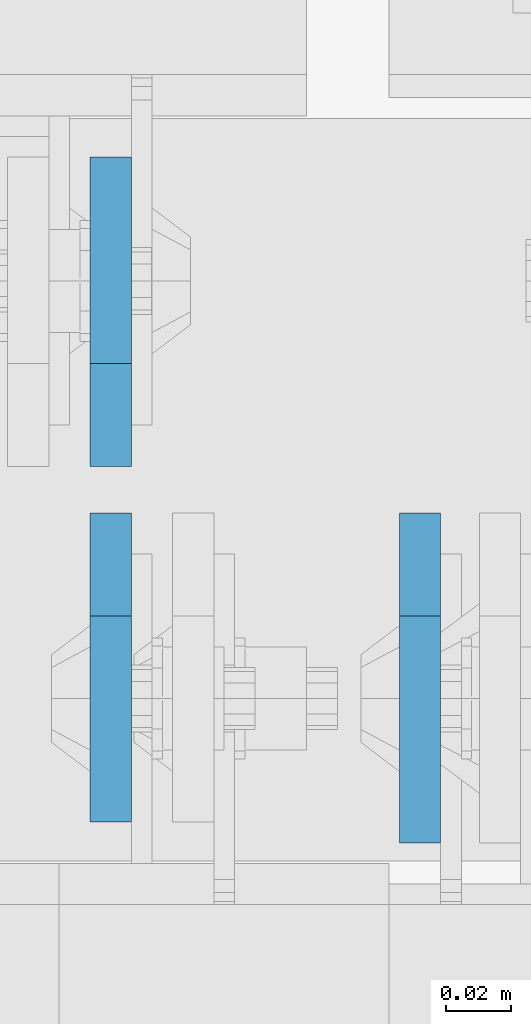
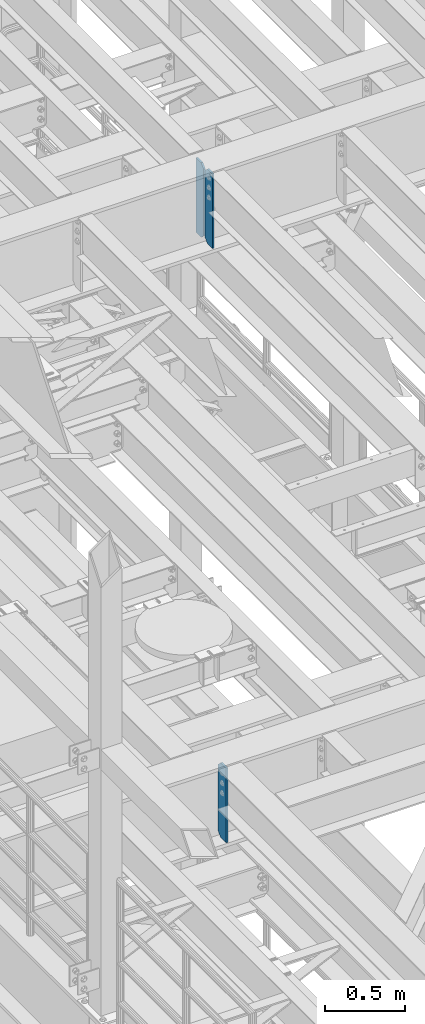
# One storey, part 1561 of 1876: 3 plates, 2 elements without a shape of their own.
"""IFC2X3 building model written with IfcOpenShell, lengths in millimetres."""

from ifc_helpers import new_model, si_unit, frame, origin_with_axes, place, context, subcontext, project, spatial, faceted_brep, material, type_object, element, aggregate, save


model = new_model("IFC2X3")

# Units and contexts
model_context = context("Model", 3, precision=1e-05, world=origin_with_axes())
body_context = subcontext(model_context, "Body", "Model", "MODEL_VIEW")
ifc_project = project(units=[si_unit("LENGTHUNIT", "METRE", prefix="MILLI"), si_unit("AREAUNIT", "SQUARE_METRE"), si_unit("VOLUMEUNIT", "CUBIC_METRE"), si_unit("MASSUNIT", "GRAM", prefix="KILO"), si_unit("TIMEUNIT", "SECOND"), si_unit("PLANEANGLEUNIT", "RADIAN"), si_unit("SOLIDANGLEUNIT", "STERADIAN"), si_unit("THERMODYNAMICTEMPERATUREUNIT", "DEGREE_CELSIUS"), si_unit("LUMINOUSINTENSITYUNIT", "LUMEN")], contexts=[model_context])

# Site, building, storey
site_placement = place(None, origin_with_axes())
site = spatial("IfcSite", under=ifc_project, at=site_placement, CompositionType="ELEMENT")
building_placement = place(site_placement, origin_with_axes())
building = spatial("IfcBuilding", under=site, at=building_placement, Name="Undefined", CompositionType="ELEMENT")
storey_placement = place(building_placement, origin_with_axes())
storey = spatial("IfcBuildingStorey", under=building, at=storey_placement, Name="Undefined", CompositionType="ELEMENT", Elevation=0.0)

# Assembly, plates
assembly_1_placement = place(storey_placement, origin_with_axes())
assembly_1 = element("IfcElementAssembly", 1, at=assembly_1_placement, inside=storey, Name="BEAM", AssemblyPlace="NOTDEFINED", PredefinedType="RIGID_FRAME")
ifc_material = material(Name="STEEL/A36")
plate_type_1 = type_object("IfcPlateType", PredefinedType="NOTDEFINED")
plate_1_placement = place(assembly_1_placement, frame((1895.47499990463, 1516.85625, 21959.8875), z_axis=(0.0, 0.0, 1.0), x_axis=(0.0, -1.0, 0.0)))
plate_1 = element("IfcPlate", 2, at=plate_1_placement, type_object=plate_type_1, material=ifc_material, Name="PLATE", context=body_context, shape_type="Brep", body=[
    faceted_brep([(0.0, -6.34999999999991, 31.75), (0.0, -6.35000000000036, 538.162475585938), (0.0, 6.35000000000036, 538.162475585938), (0.0, 6.34999999999991, 31.75), (31.75, -6.35000000000036, 569.912475585938), (31.75, 6.35000000000036, 569.912475585938), (95.25, -6.35000000000036, 569.912475585938), (95.25, 6.35000000000036, 569.912475585938), (95.25, -6.35000000000036, 0.0), (95.25, 6.35000000000036, 0.0), (31.75, -6.34999999999991, 0.0), (31.75, 6.34999999999991, 0.0)], [[[0, 1, 2, 3]], [[1, 4, 5, 2]], [[4, 6, 7, 5]], [[6, 8, 9, 7]], [[8, 10, 11, 9]], [[10, 0, 3, 11]], [[5, 7, 9, 11, 3, 2]], [[10, 8, 6, 4, 1, 0]]]),
])
plate_2_placement = place(assembly_1_placement, frame((1895.47499990463, 1531.14375, 21959.8875), z_axis=(0.0, 0.0, 1.0), x_axis=(0.0, 1.0, 0.0)))
plate_2 = element("IfcPlate", 3, at=plate_2_placement, type_object=plate_type_1, material=ifc_material, Name="PLATE", context=body_context, shape_type="Brep", body=[
    faceted_brep([(0.0, -6.34999999999991, 31.75), (0.0, -6.35000000000036, 538.162475585938), (0.0, 6.35000000000036, 538.162475585938), (0.0, 6.34999999999991, 31.75), (31.75, -6.35000000000036, 569.912475585938), (31.75, 6.35000000000036, 569.912475585938), (95.25, -6.35000000000036, 569.912475585938), (95.25, 6.35000000000036, 569.912475585938), (95.25, -6.35000000000036, 0.0), (95.25, 6.35000000000036, 0.0), (31.75, -6.34999999999991, 0.0), (31.75, 6.34999999999991, 0.0)], [[[0, 1, 2, 3]], [[1, 4, 5, 2]], [[4, 6, 7, 5]], [[6, 8, 9, 7]], [[8, 10, 11, 9]], [[10, 0, 3, 11]], [[5, 7, 9, 11, 3, 2]], [[10, 8, 6, 4, 1, 0]]]),
])
aggregate(assembly_1, [plate_1, plate_2])

# Assembly, plate
assembly_2_placement = place(storey_placement, origin_with_axes())
assembly_2 = element("IfcElementAssembly", 4, at=assembly_2_placement, inside=storey, Name="BEAM", AssemblyPlace="NOTDEFINED", PredefinedType="RIGID_FRAME")
plate_type_2 = type_object("IfcPlateType", PredefinedType="NOTDEFINED")
plate_3_placement = place(assembly_2_placement, frame((1990.72488635592, 1516.85625, 17387.8875), z_axis=(0.0, 0.0, 1.0), x_axis=(0.0, -1.0, 0.0)))
plate_3 = element("IfcPlate", 5, at=plate_3_placement, type_object=plate_type_2, material=ifc_material, Name="PLATE", context=body_context, shape_type="Brep", body=[
    faceted_brep([(0.0, -6.34999999999991, 31.75), (0.0, -6.35000000000036, 538.162475585938), (0.0, 6.35000000000036, 538.162475585938), (0.0, 6.34999999999991, 31.75), (31.75, -6.35000000000036, 569.912475585938), (31.75, 6.35000000000036, 569.912475585938), (101.599998474121, -6.34999999999991, 569.912475585938), (101.599998474121, 6.34999999999991, 569.912475585938), (101.599998474121, -6.35000000000036, 0.0), (101.599998474121, 6.35000000000036, 0.0), (31.75, -6.34999999999991, 0.0), (31.75, 6.34999999999991, 0.0)], [[[0, 1, 2, 3]], [[1, 4, 5, 2]], [[4, 6, 7, 5]], [[6, 8, 9, 7]], [[8, 10, 11, 9]], [[10, 0, 3, 11]], [[5, 7, 9, 11, 3, 2]], [[10, 8, 6, 4, 1, 0]]]),
])
aggregate(assembly_2, [plate_3])

save(model, "model.ifc")
